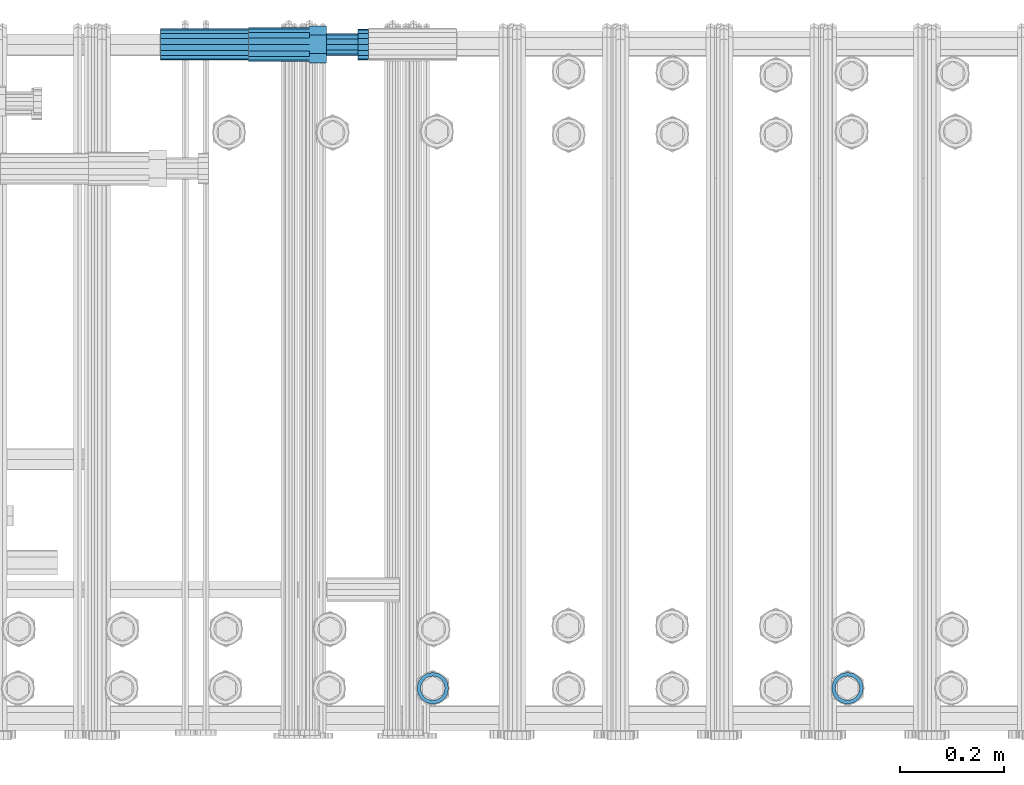
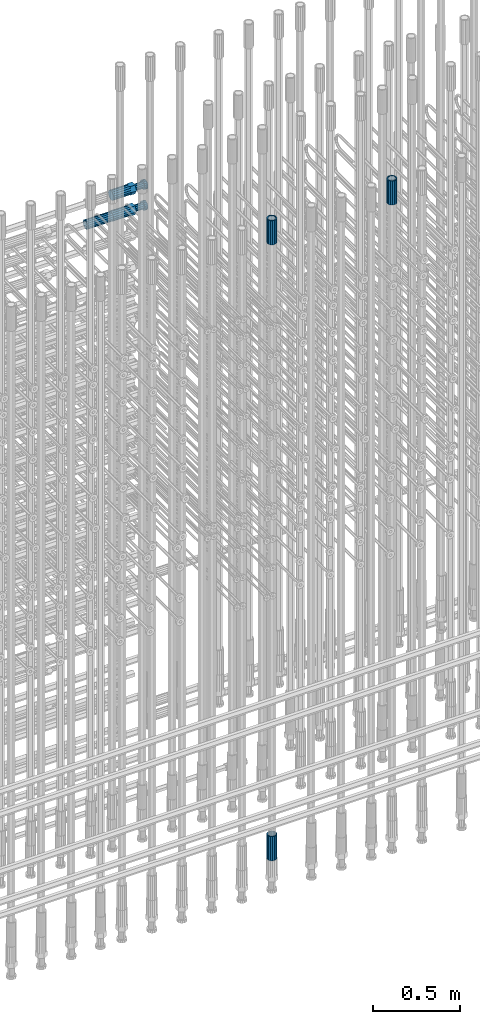
# One storey, part 56 of 177: 6 beams.
"""IFC2X3 building model written with IfcOpenShell, lengths in millimetres."""

from ifc_helpers import new_model, si_unit, frame, origin_with_axes, place, context, subcontext, project, spatial, faceted_brep, material, type_object, element, save


model = new_model("IFC2X3")

# Units and contexts
model_context_1 = context("Model", 3, precision=1e-05, world=origin_with_axes())
model_context_2 = context("Model", 3, precision=1e-05, world=origin_with_axes())
body_context = subcontext(model_context_2, "Body", "Model", "MODEL_VIEW")
ifc_project = project(units=[si_unit("LENGTHUNIT", "METRE", prefix="MILLI"), si_unit("AREAUNIT", "SQUARE_METRE"), si_unit("VOLUMEUNIT", "CUBIC_METRE"), si_unit("MASSUNIT", "GRAM", prefix="KILO"), si_unit("TIMEUNIT", "SECOND"), si_unit("PLANEANGLEUNIT", "RADIAN"), si_unit("SOLIDANGLEUNIT", "STERADIAN"), si_unit("THERMODYNAMICTEMPERATUREUNIT", "DEGREE_CELSIUS"), si_unit("LUMINOUSINTENSITYUNIT", "LUMEN")], contexts=[model_context_1])

# Site, building, storey
site_placement = place(None, origin_with_axes())
site = spatial("IfcSite", under=ifc_project, at=site_placement, CompositionType="ELEMENT")
building_placement = place(site_placement, origin_with_axes())
building = spatial("IfcBuilding", under=site, at=building_placement, Name="Undefined", CompositionType="ELEMENT")
storey_placement = place(building_placement, origin_with_axes())
storey = spatial("IfcBuildingStorey", under=building, at=storey_placement, Name="Undefined", CompositionType="ELEMENT", Elevation=0.0)

# Beams
ifc_material = material(Name="STEEL/S275")
beam_type_1 = type_object("IfcBeamType", PredefinedType="NOTDEFINED")
beam_1_placement = place(storey_placement, frame((2031974.00256183, 6205157.35759348, 22659.9858194822), z_axis=(1.0, 0.0, 0.0), x_axis=(0.0, 0.0, 1.0)))
element("IfcBeam", 1, at=beam_1_placement, inside=storey, type_object=beam_type_1, material=ifc_material, Name="AG40N", context=body_context, shape_type="Brep", body=[
    faceted_brep([(0.0, -23.5000000001164, -9.31322574615479e-10), (0.0, -21.7111690140155, 8.99306066054851), (170.0, -21.7111690140155, 8.99306066054851), (170.0, -23.5, 0.0), (0.0, -16.6170093578839, 16.6170093575493), (170.0, -16.6170093578839, 16.6170093575493), (0.0, -8.99306066057943, 21.7111690137535), (170.0, -8.99306066057943, 21.7111690137535), (0.0, 1.16415321826935e-10, 23.5), (170.0, 0.0, 23.5), (0.0, 8.99306066057943, 21.7111690137535), (170.0, 8.99306066057943, 21.7111690137535), (0.0, 16.6170093578839, 16.6170093575493), (170.0, 16.6170093578839, 16.6170093575493), (0.0, 21.7111690140155, 8.99306066054851), (170.0, 21.7111690140155, 8.99306066054851), (0.0, 23.5000000001164, -9.31322574615479e-10), (170.0, 23.5, 0.0), (0.0, 21.7111690140155, -8.99306066054851), (170.0, 21.7111690140155, -8.99306066054851), (0.0, 16.6170093578839, -16.6170093575493), (170.0, 16.6170093578839, -16.6170093575493), (0.0, 8.99306066057943, -21.7111690137535), (170.0, 8.99306066057943, -21.7111690137535), (0.0, 1.16415321826935e-10, -23.5000000009313), (170.0, 0.0, -23.5), (0.0, -8.99306066057943, -21.7111690137535), (170.0, -8.99306066057943, -21.7111690137535), (0.0, -16.6170093578839, -16.6170093575493), (170.0, -16.6170093578839, -16.6170093575493), (0.0, -21.7111690140155, -8.99306066054851), (170.0, -21.7111690140155, -8.99306066054851), (0.0, -30.5, 0.0), (0.0, -28.1783257415937, -11.6718446873128), (170.0, -28.1783257415937, -11.6718446873128), (170.0, -30.5, 0.0), (0.0, -21.5667568261888, -21.5667568258941), (170.0, -21.5667568261888, -21.5667568258941), (0.0, -11.6718446871346, -28.1783257415518), (170.0, -11.6718446871346, -28.1783257415518), (0.0, 0.0, -30.5), (170.0, 0.0, -30.5), (0.0, 11.6718446871346, -28.1783257415518), (170.0, 11.6718446871346, -28.1783257415518), (0.0, 21.5667568261888, -21.5667568258941), (170.0, 21.5667568261888, -21.5667568258941), (0.0, 28.1783257415937, -11.6718446873128), (170.0, 28.1783257415937, -11.6718446873128), (0.0, 30.5, 0.0), (170.0, 30.5, 0.0), (0.0, 28.1783257415937, 11.6718446873128), (170.0, 28.1783257415937, 11.6718446873128), (0.0, 21.5667568261888, 21.5667568258941), (170.0, 21.5667568261888, 21.5667568258941), (0.0, 11.6718446871346, 28.1783257415518), (170.0, 11.6718446871346, 28.1783257415518), (0.0, 0.0, 30.5), (170.0, 0.0, 30.5), (0.0, -11.6718446871346, 28.1783257415518), (170.0, -11.6718446871346, 28.1783257415518), (0.0, -21.5667568261888, 21.5667568258941), (170.0, -21.5667568261888, 21.5667568258941), (0.0, -28.1783257415937, 11.6718446873128), (170.0, -28.1783257415937, 11.6718446873128)], [[[0, 1, 2, 3]], [[1, 4, 5, 2]], [[4, 6, 7, 5]], [[6, 8, 9, 7]], [[8, 10, 11, 9]], [[10, 12, 13, 11]], [[12, 14, 15, 13]], [[14, 16, 17, 15]], [[16, 18, 19, 17]], [[18, 20, 21, 19]], [[20, 22, 23, 21]], [[22, 24, 25, 23]], [[24, 26, 27, 25]], [[26, 28, 29, 27]], [[28, 30, 31, 29]], [[30, 0, 3, 31]], [[32, 33, 34, 35]], [[33, 36, 37, 34]], [[36, 38, 39, 37]], [[38, 40, 41, 39]], [[40, 42, 43, 41]], [[42, 44, 45, 43]], [[44, 46, 47, 45]], [[46, 48, 49, 47]], [[48, 50, 51, 49]], [[50, 52, 53, 51]], [[52, 54, 55, 53]], [[54, 56, 57, 55]], [[56, 58, 59, 57]], [[58, 60, 61, 59]], [[60, 62, 63, 61]], [[62, 32, 35, 63]], [[37, 39, 41, 43, 45, 47, 49, 51, 53, 55, 57, 59, 61, 63, 35, 34], [5, 7, 9, 11, 13, 15, 17, 19, 21, 23, 25, 27, 29, 31, 3, 2]], [[62, 60, 58, 56, 54, 52, 50, 48, 46, 44, 42, 40, 38, 36, 33, 32], [30, 28, 26, 24, 22, 20, 18, 16, 14, 12, 10, 8, 6, 4, 1, 0]]]),
])
beam_2_placement = place(storey_placement, frame((2032774.00256055, 6205157.39829884, 22659.9858194822), z_axis=(1.0, 0.0, 0.0), x_axis=(0.0, 0.0, 1.0)))
element("IfcBeam", 2, at=beam_2_placement, inside=storey, type_object=beam_type_1, material=ifc_material, Name="AG40N", context=body_context, shape_type="Brep", body=[
    faceted_brep([(0.0, -23.5000000001164, -9.31322574615479e-10), (0.0, -21.7111690140155, 8.99306066054851), (170.0, -21.7111690140155, 8.99306066054851), (170.0, -23.5, 0.0), (0.0, -16.6170093578839, 16.6170093575493), (170.0, -16.6170093578839, 16.6170093575493), (0.0, -8.99306066057943, 21.7111690137535), (170.0, -8.99306066057943, 21.7111690137535), (0.0, 1.16415321826935e-10, 23.5), (170.0, 0.0, 23.5), (0.0, 8.99306066057943, 21.7111690137535), (170.0, 8.99306066057943, 21.7111690137535), (0.0, 16.6170093578839, 16.6170093575493), (170.0, 16.6170093578839, 16.6170093575493), (0.0, 21.7111690140155, 8.99306066054851), (170.0, 21.7111690140155, 8.99306066054851), (0.0, 23.5000000001164, -9.31322574615479e-10), (170.0, 23.5, 0.0), (0.0, 21.7111690140155, -8.99306066054851), (170.0, 21.7111690140155, -8.99306066054851), (0.0, 16.6170093578839, -16.6170093575493), (170.0, 16.6170093578839, -16.6170093575493), (0.0, 8.99306066057943, -21.7111690137535), (170.0, 8.99306066057943, -21.7111690137535), (0.0, 1.16415321826935e-10, -23.5000000009313), (170.0, 0.0, -23.5), (0.0, -8.99306066057943, -21.7111690137535), (170.0, -8.99306066057943, -21.7111690137535), (0.0, -16.6170093578839, -16.6170093575493), (170.0, -16.6170093578839, -16.6170093575493), (0.0, -21.7111690140155, -8.99306066054851), (170.0, -21.7111690140155, -8.99306066054851), (0.0, -30.5, 0.0), (0.0, -28.1783257415937, -11.6718446873128), (170.0, -28.1783257415937, -11.6718446873128), (170.0, -30.5, 0.0), (0.0, -21.5667568261888, -21.5667568258941), (170.0, -21.5667568261888, -21.5667568258941), (0.0, -11.6718446871346, -28.1783257415518), (170.0, -11.6718446871346, -28.1783257415518), (0.0, 0.0, -30.5), (170.0, 0.0, -30.5), (0.0, 11.6718446871346, -28.1783257415518), (170.0, 11.6718446871346, -28.1783257415518), (0.0, 21.5667568261888, -21.5667568258941), (170.0, 21.5667568261888, -21.5667568258941), (0.0, 28.1783257415937, -11.6718446873128), (170.0, 28.1783257415937, -11.6718446873128), (0.0, 30.5, 0.0), (170.0, 30.5, 0.0), (0.0, 28.1783257415937, 11.6718446873128), (170.0, 28.1783257415937, 11.6718446873128), (0.0, 21.5667568261888, 21.5667568258941), (170.0, 21.5667568261888, 21.5667568258941), (0.0, 11.6718446871346, 28.1783257415518), (170.0, 11.6718446871346, 28.1783257415518), (0.0, 0.0, 30.5), (170.0, 0.0, 30.5), (0.0, -11.6718446871346, 28.1783257415518), (170.0, -11.6718446871346, 28.1783257415518), (0.0, -21.5667568261888, 21.5667568258941), (170.0, -21.5667568261888, 21.5667568258941), (0.0, -28.1783257415937, 11.6718446873128), (170.0, -28.1783257415937, 11.6718446873128)], [[[0, 1, 2, 3]], [[1, 4, 5, 2]], [[4, 6, 7, 5]], [[6, 8, 9, 7]], [[8, 10, 11, 9]], [[10, 12, 13, 11]], [[12, 14, 15, 13]], [[14, 16, 17, 15]], [[16, 18, 19, 17]], [[18, 20, 21, 19]], [[20, 22, 23, 21]], [[22, 24, 25, 23]], [[24, 26, 27, 25]], [[26, 28, 29, 27]], [[28, 30, 31, 29]], [[30, 0, 3, 31]], [[32, 33, 34, 35]], [[33, 36, 37, 34]], [[36, 38, 39, 37]], [[38, 40, 41, 39]], [[40, 42, 43, 41]], [[42, 44, 45, 43]], [[44, 46, 47, 45]], [[46, 48, 49, 47]], [[48, 50, 51, 49]], [[50, 52, 53, 51]], [[52, 54, 55, 53]], [[54, 56, 57, 55]], [[56, 58, 59, 57]], [[58, 60, 61, 59]], [[60, 62, 63, 61]], [[62, 32, 35, 63]], [[37, 39, 41, 43, 45, 47, 49, 51, 53, 55, 57, 59, 61, 63, 35, 34], [5, 7, 9, 11, 13, 15, 17, 19, 21, 23, 25, 27, 29, 31, 3, 2]], [[62, 60, 58, 56, 54, 52, 50, 48, 46, 44, 42, 40, 38, 36, 33, 32], [30, 28, 26, 24, 22, 20, 18, 16, 14, 12, 10, 8, 6, 4, 1, 0]]]),
])
beam_3_placement = place(storey_placement, frame((2031974.00256183, 6205157.35759347, 18490.9668004279), z_axis=(-1.0, 0.0, 0.0), x_axis=(0.0, 0.0, -1.0)))
element("IfcBeam", 3, at=beam_3_placement, inside=storey, type_object=beam_type_1, material=ifc_material, Name="AG40N", context=body_context, shape_type="Brep", body=[
    faceted_brep([(0.0, -23.5000000001164, -9.31322574615479e-10), (0.0, -21.7111690140155, 8.99306066054851), (170.0, -21.7111690140155, 8.99306066054851), (170.0, -23.5, 0.0), (0.0, -16.6170093578839, 16.6170093575493), (170.0, -16.6170093578839, 16.6170093575493), (0.0, -8.99306066057943, 21.7111690137535), (170.0, -8.99306066057943, 21.7111690137535), (0.0, 1.16415321826935e-10, 23.5), (170.0, 0.0, 23.5), (0.0, 8.99306066057943, 21.7111690137535), (170.0, 8.99306066057943, 21.7111690137535), (0.0, 16.6170093578839, 16.6170093575493), (170.0, 16.6170093578839, 16.6170093575493), (0.0, 21.7111690140155, 8.99306066054851), (170.0, 21.7111690140155, 8.99306066054851), (0.0, 23.5000000001164, -9.31322574615479e-10), (170.0, 23.5, 0.0), (0.0, 21.7111690140155, -8.99306066054851), (170.0, 21.7111690140155, -8.99306066054851), (0.0, 16.6170093578839, -16.6170093575493), (170.0, 16.6170093578839, -16.6170093575493), (0.0, 8.99306066057943, -21.7111690137535), (170.0, 8.99306066057943, -21.7111690137535), (0.0, 1.16415321826935e-10, -23.5000000009313), (170.0, 0.0, -23.5), (0.0, -8.99306066057943, -21.7111690137535), (170.0, -8.99306066057943, -21.7111690137535), (0.0, -16.6170093578839, -16.6170093575493), (170.0, -16.6170093578839, -16.6170093575493), (0.0, -21.7111690140155, -8.99306066054851), (170.0, -21.7111690140155, -8.99306066054851), (0.0, -30.5, 0.0), (0.0, -28.1783257415937, -11.6718446873128), (170.0, -28.1783257415937, -11.6718446873128), (170.0, -30.5, 0.0), (0.0, -21.5667568261888, -21.5667568258941), (170.0, -21.5667568261888, -21.5667568258941), (0.0, -11.6718446871346, -28.1783257415518), (170.0, -11.6718446871346, -28.1783257415518), (0.0, 0.0, -30.5), (170.0, 0.0, -30.5), (0.0, 11.6718446871346, -28.1783257415518), (170.0, 11.6718446871346, -28.1783257415518), (0.0, 21.5667568261888, -21.5667568258941), (170.0, 21.5667568261888, -21.5667568258941), (0.0, 28.1783257415937, -11.6718446873128), (170.0, 28.1783257415937, -11.6718446873128), (0.0, 30.5, 0.0), (170.0, 30.5, 0.0), (0.0, 28.1783257415937, 11.6718446873128), (170.0, 28.1783257415937, 11.6718446873128), (0.0, 21.5667568261888, 21.5667568258941), (170.0, 21.5667568261888, 21.5667568258941), (0.0, 11.6718446871346, 28.1783257415518), (170.0, 11.6718446871346, 28.1783257415518), (0.0, 0.0, 30.5), (170.0, 0.0, 30.5), (0.0, -11.6718446871346, 28.1783257415518), (170.0, -11.6718446871346, 28.1783257415518), (0.0, -21.5667568261888, 21.5667568258941), (170.0, -21.5667568261888, 21.5667568258941), (0.0, -28.1783257415937, 11.6718446873128), (170.0, -28.1783257415937, 11.6718446873128)], [[[0, 1, 2, 3]], [[1, 4, 5, 2]], [[4, 6, 7, 5]], [[6, 8, 9, 7]], [[8, 10, 11, 9]], [[10, 12, 13, 11]], [[12, 14, 15, 13]], [[14, 16, 17, 15]], [[16, 18, 19, 17]], [[18, 20, 21, 19]], [[20, 22, 23, 21]], [[22, 24, 25, 23]], [[24, 26, 27, 25]], [[26, 28, 29, 27]], [[28, 30, 31, 29]], [[30, 0, 3, 31]], [[32, 33, 34, 35]], [[33, 36, 37, 34]], [[36, 38, 39, 37]], [[38, 40, 41, 39]], [[40, 42, 43, 41]], [[42, 44, 45, 43]], [[44, 46, 47, 45]], [[46, 48, 49, 47]], [[48, 50, 51, 49]], [[50, 52, 53, 51]], [[52, 54, 55, 53]], [[54, 56, 57, 55]], [[56, 58, 59, 57]], [[58, 60, 61, 59]], [[60, 62, 63, 61]], [[62, 32, 35, 63]], [[37, 39, 41, 43, 45, 47, 49, 51, 53, 55, 57, 59, 61, 63, 35, 34], [5, 7, 9, 11, 13, 15, 17, 19, 21, 23, 25, 27, 29, 31, 3, 2]], [[62, 60, 58, 56, 54, 52, 50, 48, 46, 44, 42, 40, 38, 36, 33, 32], [30, 28, 26, 24, 22, 20, 18, 16, 14, 12, 10, 8, 6, 4, 1, 0]]]),
])
beam_4_placement = place(storey_placement, frame((2031449.01847313, 6206398.98588032, 22212.9868004311), z_axis=(0.0, 0.0, -1.0), x_axis=(1.0, 0.0, 0.0)))
element("IfcBeam", 4, at=beam_4_placement, inside=storey, type_object=beam_type_1, material=ifc_material, Name="AG40N", context=body_context, shape_type="Brep", body=[
    faceted_brep([(0.0, -23.5000000001164, -9.31322574615479e-10), (0.0, -21.7111690140155, 8.99306066054851), (170.0, -21.7111690140155, 8.99306066054851), (170.0, -23.5, 0.0), (0.0, -16.6170093578839, 16.6170093575493), (170.0, -16.6170093578839, 16.6170093575493), (0.0, -8.99306066057943, 21.7111690137535), (170.0, -8.99306066057943, 21.7111690137535), (0.0, 1.16415321826935e-10, 23.5), (170.0, 0.0, 23.5), (0.0, 8.99306066057943, 21.7111690137535), (170.0, 8.99306066057943, 21.7111690137535), (0.0, 16.6170093578839, 16.6170093575493), (170.0, 16.6170093578839, 16.6170093575493), (0.0, 21.7111690140155, 8.99306066054851), (170.0, 21.7111690140155, 8.99306066054851), (0.0, 23.5000000001164, -9.31322574615479e-10), (170.0, 23.5, 0.0), (0.0, 21.7111690140155, -8.99306066054851), (170.0, 21.7111690140155, -8.99306066054851), (0.0, 16.6170093578839, -16.6170093575493), (170.0, 16.6170093578839, -16.6170093575493), (0.0, 8.99306066057943, -21.7111690137535), (170.0, 8.99306066057943, -21.7111690137535), (0.0, 1.16415321826935e-10, -23.5000000009313), (170.0, 0.0, -23.5), (0.0, -8.99306066057943, -21.7111690137535), (170.0, -8.99306066057943, -21.7111690137535), (0.0, -16.6170093578839, -16.6170093575493), (170.0, -16.6170093578839, -16.6170093575493), (0.0, -21.7111690140155, -8.99306066054851), (170.0, -21.7111690140155, -8.99306066054851), (0.0, -30.5, 0.0), (0.0, -28.1783257415937, -11.6718446873128), (170.0, -28.1783257415937, -11.6718446873128), (170.0, -30.5, 0.0), (0.0, -21.5667568261888, -21.5667568258941), (170.0, -21.5667568261888, -21.5667568258941), (0.0, -11.6718446871346, -28.1783257415518), (170.0, -11.6718446871346, -28.1783257415518), (0.0, 0.0, -30.5), (170.0, 0.0, -30.5), (0.0, 11.6718446871346, -28.1783257415518), (170.0, 11.6718446871346, -28.1783257415518), (0.0, 21.5667568261888, -21.5667568258941), (170.0, 21.5667568261888, -21.5667568258941), (0.0, 28.1783257415937, -11.6718446873128), (170.0, 28.1783257415937, -11.6718446873128), (0.0, 30.5, 0.0), (170.0, 30.5, 0.0), (0.0, 28.1783257415937, 11.6718446873128), (170.0, 28.1783257415937, 11.6718446873128), (0.0, 21.5667568261888, 21.5667568258941), (170.0, 21.5667568261888, 21.5667568258941), (0.0, 11.6718446871346, 28.1783257415518), (170.0, 11.6718446871346, 28.1783257415518), (0.0, 0.0, 30.5), (170.0, 0.0, 30.5), (0.0, -11.6718446871346, 28.1783257415518), (170.0, -11.6718446871346, 28.1783257415518), (0.0, -21.5667568261888, 21.5667568258941), (170.0, -21.5667568261888, 21.5667568258941), (0.0, -28.1783257415937, 11.6718446873128), (170.0, -28.1783257415937, 11.6718446873128)], [[[0, 1, 2, 3]], [[1, 4, 5, 2]], [[4, 6, 7, 5]], [[6, 8, 9, 7]], [[8, 10, 11, 9]], [[10, 12, 13, 11]], [[12, 14, 15, 13]], [[14, 16, 17, 15]], [[16, 18, 19, 17]], [[18, 20, 21, 19]], [[20, 22, 23, 21]], [[22, 24, 25, 23]], [[24, 26, 27, 25]], [[26, 28, 29, 27]], [[28, 30, 31, 29]], [[30, 0, 3, 31]], [[32, 33, 34, 35]], [[33, 36, 37, 34]], [[36, 38, 39, 37]], [[38, 40, 41, 39]], [[40, 42, 43, 41]], [[42, 44, 45, 43]], [[44, 46, 47, 45]], [[46, 48, 49, 47]], [[48, 50, 51, 49]], [[50, 52, 53, 51]], [[52, 54, 55, 53]], [[54, 56, 57, 55]], [[56, 58, 59, 57]], [[58, 60, 61, 59]], [[60, 62, 63, 61]], [[62, 32, 35, 63]], [[37, 39, 41, 43, 45, 47, 49, 51, 53, 55, 57, 59, 61, 63, 35, 34], [5, 7, 9, 11, 13, 15, 17, 19, 21, 23, 25, 27, 29, 31, 3, 2]], [[62, 60, 58, 56, 54, 52, 50, 48, 46, 44, 42, 40, 38, 36, 33, 32], [30, 28, 26, 24, 22, 20, 18, 16, 14, 12, 10, 8, 6, 4, 1, 0]]]),
])
beam_type_2 = type_object("IfcBeamType", Name="ROD65", PredefinedType="NOTDEFINED")
beam_5_placement = place(storey_placement, frame((2031619.01847313, 6206398.98588031, 22359.9868004311), z_axis=(0.0, 0.0, -1.0), x_axis=(1.0, 0.0, 0.0)))
element("IfcBeam", 5, at=beam_5_placement, inside=storey, type_object=beam_type_2, material=ifc_material, Name="AGB40", ObjectType="ROD65", context=body_context, shape_type="Brep", body=[
    faceted_brep([(117.0, 8.17543110251427, 30.873805644922), (117.0, 17.8250000001863, 30.873805644922), (117.0, 22.0056958701462, 23.6326279877685), (117.0, 12.4372115517035, 30.0260848065373), (117.0, -17.8250000001863, 30.873805644922), (150.200000000186, -17.8250000001863, 30.873805644922), (150.200000000186, 17.8250000001863, 30.873805644922), (117.0, -8.17543110251427, 30.873805644922), (117.0, -12.4372115517035, 30.0260848065373), (117.0, -22.0056958701462, 23.6326279877685), (117.0, -35.6500000003725, 0.0), (150.200000000186, -35.6500000003725, 0.0), (117.0, -30.8443150008097, 8.32369058486074), (117.0, -32.5, 0.0), (117.0, -30.8443150008097, -8.32369058462791), (117.0, -17.8250000001863, -30.873805644922), (150.200000000186, -17.8250000001863, -30.873805644922), (117.0, -22.0056958701462, -23.6326279877685), (117.0, -12.4372115517035, -30.0260848065373), (117.0, -8.17543110251427, -30.873805644922), (117.0, 17.8250000001863, -30.873805644922), (150.200000000186, 17.8250000001863, -30.873805644922), (117.0, 8.17543110251427, -30.873805644922), (117.0, 22.0056958701462, -23.6326279877685), (117.0, 12.4372115517035, -30.0260848065373), (117.0, 35.6500000003725, 0.0), (150.200000000186, 35.6500000003725, 0.0), (117.0, 30.8443150008097, -8.32369058486074), (117.0, 30.8443150008097, 8.32369058462791), (117.0, 32.5, 0.0), (0.0, -22.9809703892097, 22.9809703885621), (0.0, -30.0260848058388, 12.4372115518636), (117.0, -30.0260848067701, 12.4372115519363), (117.0, -22.9809703882784, 22.9809703885112), (-2.3283064365387e-10, 22.9809703892097, -22.9809703885639), (-4.65661287307739e-10, 30.0260848077014, -12.4372115518672), (117.0, 30.0260848067701, -12.4372115519363), (117.0, 22.9809703882784, -22.9809703885112), (-2.3283064365387e-10, -30.0260848067701, -12.4372115518672), (-2.3283064365387e-10, -22.9809703892097, -22.9809703885621), (117.0, -22.9809703882784, -22.9809703885112), (117.0, -30.0260848067701, -12.4372115519363), (-2.3283064365387e-10, -12.4372115507722, 30.0260848066137), (-2.3283064365387e-10, 9.31322574615479e-10, 32.4999999999982), (-2.3283064365387e-10, 12.4372115526348, 30.0260848066137), (0.0, 22.9809703892097, 22.9809703885621), (-2.3283064365387e-10, 30.0260848077014, 12.4372115518636), (-2.3283064365387e-10, 32.5, 0.0), (-2.3283064365387e-10, 12.4372115526348, -30.0260848066173), (-2.3283064365387e-10, 9.31322574615479e-10, -32.5), (-2.3283064365387e-10, -12.4372115517035, -30.0260848066173), (-4.65661287307739e-10, -32.4999999990687, -1.81898940354586e-12), (117.0, 22.9809703882784, 22.9809703885112), (117.0, 30.0260848067701, 12.4372115519363), (117.0, 0.0, -32.5), (117.0, 0.0, 32.5), (150.200000000186, 10.5, -18.1865334794857), (150.200000000186, 0.0, -21.0), (150.200000000186, -10.5, -18.1865334794857), (150.200000000186, -18.18653347902, -10.5), (150.200000000186, -21.0, 0.0), (150.200000000186, -18.18653347902, 10.5), (150.200000000186, -10.5, 18.1865334794857), (150.200000000186, 0.0, 21.0), (150.200000000186, 10.5, 18.1865334794857), (150.200000000186, 18.18653347902, 10.5), (150.200000000186, 21.0, 0.0), (150.200000000186, 18.18653347902, -10.5), (210.980000000447, -18.18653347902, 10.5), (210.980000000447, -21.0, 0.0), (210.980000000447, -10.5, 18.1865334794857), (210.980000000447, 0.0, 21.0), (210.980000000447, 10.5, 18.1865334794857), (210.980000000447, 18.18653347902, 10.5), (210.980000000447, 21.0, 0.0), (210.980000000447, 18.18653347902, -10.5), (210.980000000447, 10.5, -18.1865334794857), (210.980000000447, 0.0, -21.0), (210.980000000447, -10.5, -18.1865334794857), (210.980000000447, -18.18653347902, -10.5), (211.001368442696, -27.7269937992096, -11.491116326768), (211.003082550167, -21.2238094303757, -21.223815418547), (231.002518367059, -21.2131944671273, -21.2132004550658), (231.000804259587, -27.7163788359612, -11.4805013632867), (211.001368440451, -11.4911085031927, -27.7269970395137), (231.000804257343, -11.4804935399443, -27.7163820760325), (210.996487071217, -0.0106065049767494, -30.0106107392348), (230.995922888109, 8.45827162265778e-06, -29.9999957757536), (210.989181586672, 11.46989420522, -27.7269970329944), (230.988617403564, 11.4805091684684, -27.7163820695132), (210.980564180623, 21.2025914648548, -21.2238154064398), (230.979999997515, 21.2132064281031, -21.2132004429586), (210.971946775022, 27.7057703435421, -11.4911163107026), (230.971382591913, 27.7163853067905, -11.4805013472214), (210.96464129175, 29.9893808094785, -0.0106149562634528), (230.964077108642, 29.9999957727268, 7.21774995326996e-09), (210.959759924415, 27.7057638689876, 11.4698863970116), (230.959195741307, 27.7163788322359, 11.4805013604928), (210.958045816944, 21.2025795001537, 21.2025854887906), (230.957481633835, 21.213194463402, 21.2132004522718), (210.95975992666, 11.4698785729706, 27.7057671097573), (230.959195743551, 11.480493536219, 27.7163820732385), (210.964641295894, -0.010623425245285, 29.9893808094785), (230.964077112785, -8.46199691295624e-06, 29.9999957729597), (210.971946780439, -11.4911241354421, 27.705767103238), (230.97138259733, -11.4805091721937, 27.7163820667192), (210.980564186488, -21.2238213950768, 21.2025854766835), (230.980000003379, -21.2132064318284, 21.2132004401647), (210.989181592089, -27.7270002737641, 11.4698863809463), (230.988617408981, -27.7163853105158, 11.4805013444275), (210.996487075361, -30.0106107397005, -0.0106149734929204), (230.995922892253, -29.9999957764521, -1.00117176771164e-08)], [[[0, 1, 2, 3]], [[4, 5, 6, 1, 0, 7]], [[4, 7, 8, 9]], [[10, 11, 5, 4, 9, 12]], [[10, 12, 13, 14]], [[15, 16, 11, 10, 14, 17]], [[15, 17, 18, 19]], [[20, 21, 16, 15, 19, 22]], [[23, 20, 22, 24]], [[25, 26, 21, 20, 23, 27]], [[28, 25, 27, 29]], [[30, 31, 32, 33]], [[34, 35, 36, 37]], [[38, 39, 40, 41]], [[31, 30, 42, 43, 44, 45, 46, 47, 35, 34, 48, 49, 50, 39, 38, 51]], [[46, 45, 52, 53]], [[29, 47, 46, 53, 28]], [[27, 36, 35, 47, 29]], [[23, 37, 36, 27]], [[24, 48, 34, 37, 23]], [[22, 54, 49, 48, 24]], [[19, 54, 22]], [[18, 50, 49, 54, 19]], [[17, 40, 39, 50, 18]], [[14, 41, 40, 17]], [[13, 51, 38, 41, 14]], [[12, 32, 31, 51, 13]], [[9, 33, 32, 12]], [[8, 42, 30, 33, 9]], [[7, 55, 43, 42, 8]], [[0, 55, 7]], [[3, 44, 43, 55, 0]], [[2, 52, 45, 44, 3]], [[28, 53, 52, 2]], [[1, 6, 26, 25, 28, 2]], [[5, 11, 16, 21, 26, 6], [56, 57, 58, 59, 60, 61, 62, 63, 64, 65, 66, 67]], [[68, 61, 60, 69]], [[70, 62, 61, 68]], [[71, 63, 62, 70]], [[72, 64, 63, 71]], [[73, 65, 64, 72]], [[74, 66, 65, 73]], [[75, 67, 66, 74]], [[76, 56, 67, 75]], [[77, 57, 56, 76]], [[78, 58, 57, 77]], [[79, 59, 58, 78]], [[69, 60, 59, 79]], [[80, 81, 82, 83]], [[81, 84, 85, 82]], [[84, 86, 87, 85]], [[86, 88, 89, 87]], [[88, 90, 91, 89]], [[90, 92, 93, 91]], [[92, 94, 95, 93]], [[94, 96, 97, 95]], [[96, 98, 99, 97]], [[98, 100, 101, 99]], [[100, 102, 103, 101]], [[102, 104, 105, 103]], [[104, 106, 107, 105]], [[106, 108, 109, 107]], [[108, 110, 111, 109]], [[82, 85, 87, 89, 91, 93, 95, 97, 99, 101, 103, 105, 107, 109, 111, 83]], [[110, 80, 83, 111]], [[108, 106, 104, 102, 100, 98, 96, 94, 92, 90, 88, 86, 84, 81, 80, 110], [75, 74, 73, 72, 71, 70, 68, 69, 79, 78, 77, 76]]]),
])
beam_6_placement = place(storey_placement, frame((2031619.01847313, 6206398.98588032, 22212.9868004311), z_axis=(0.0, 0.0, -1.0), x_axis=(1.0, 0.0, 0.0)))
element("IfcBeam", 6, at=beam_6_placement, inside=storey, type_object=beam_type_2, material=ifc_material, Name="AGB40", ObjectType="ROD65", context=body_context, shape_type="Brep", body=[
    faceted_brep([(117.0, 8.17543110251427, 30.873805644922), (117.0, 17.8250000001863, 30.873805644922), (117.0, 22.0056958701462, 23.6326279877685), (117.0, 12.4372115517035, 30.0260848065373), (117.0, -17.8250000001863, 30.873805644922), (150.200000000186, -17.8250000001863, 30.873805644922), (150.200000000186, 17.8250000001863, 30.873805644922), (117.0, -8.17543110251427, 30.873805644922), (117.0, -12.4372115517035, 30.0260848065373), (117.0, -22.0056958701462, 23.6326279877685), (117.0, -35.6500000003725, 0.0), (150.200000000186, -35.6500000003725, 0.0), (117.0, -30.8443150008097, 8.32369058486074), (117.0, -32.5, 0.0), (117.0, -30.8443150008097, -8.32369058462791), (117.0, -17.8250000001863, -30.873805644922), (150.200000000186, -17.8250000001863, -30.873805644922), (117.0, -22.0056958701462, -23.6326279877685), (117.0, -12.4372115517035, -30.0260848065373), (117.0, -8.17543110251427, -30.873805644922), (117.0, 17.8250000001863, -30.873805644922), (150.200000000186, 17.8250000001863, -30.873805644922), (117.0, 8.17543110251427, -30.873805644922), (117.0, 22.0056958701462, -23.6326279877685), (117.0, 12.4372115517035, -30.0260848065373), (117.0, 35.6500000003725, 0.0), (150.200000000186, 35.6500000003725, 0.0), (117.0, 30.8443150008097, -8.32369058486074), (117.0, 30.8443150008097, 8.32369058462791), (117.0, 32.5, 0.0), (0.0, -22.9809703892097, 22.9809703885621), (0.0, -30.0260848058388, 12.4372115518636), (117.0, -30.0260848067701, 12.4372115519363), (117.0, -22.9809703882784, 22.9809703885112), (-2.3283064365387e-10, 22.9809703892097, -22.9809703885639), (-4.65661287307739e-10, 30.0260848077014, -12.4372115518672), (117.0, 30.0260848067701, -12.4372115519363), (117.0, 22.9809703882784, -22.9809703885112), (-2.3283064365387e-10, -30.0260848067701, -12.4372115518672), (-2.3283064365387e-10, -22.9809703892097, -22.9809703885621), (117.0, -22.9809703882784, -22.9809703885112), (117.0, -30.0260848067701, -12.4372115519363), (-2.3283064365387e-10, -12.4372115507722, 30.0260848066137), (-2.3283064365387e-10, 9.31322574615479e-10, 32.4999999999982), (-2.3283064365387e-10, 12.4372115526348, 30.0260848066137), (0.0, 22.9809703892097, 22.9809703885621), (-2.3283064365387e-10, 30.0260848077014, 12.4372115518636), (-2.3283064365387e-10, 32.5, 0.0), (-2.3283064365387e-10, 12.4372115526348, -30.0260848066173), (-2.3283064365387e-10, 9.31322574615479e-10, -32.5), (-2.3283064365387e-10, -12.4372115517035, -30.0260848066173), (-4.65661287307739e-10, -32.4999999990687, -1.81898940354586e-12), (117.0, 22.9809703882784, 22.9809703885112), (117.0, 30.0260848067701, 12.4372115519363), (117.0, 0.0, -32.5), (117.0, 0.0, 32.5), (150.200000000186, 10.5, -18.1865334794857), (150.200000000186, 0.0, -21.0), (150.200000000186, -10.5, -18.1865334794857), (150.200000000186, -18.18653347902, -10.5), (150.200000000186, -21.0, 0.0), (150.200000000186, -18.18653347902, 10.5), (150.200000000186, -10.5, 18.1865334794857), (150.200000000186, 0.0, 21.0), (150.200000000186, 10.5, 18.1865334794857), (150.200000000186, 18.18653347902, 10.5), (150.200000000186, 21.0, 0.0), (150.200000000186, 18.18653347902, -10.5), (210.980000000447, -18.18653347902, 10.5), (210.980000000447, -21.0, 0.0), (210.980000000447, -10.5, 18.1865334794857), (210.980000000447, 0.0, 21.0), (210.980000000447, 10.5, 18.1865334794857), (210.980000000447, 18.18653347902, 10.5), (210.980000000447, 21.0, 0.0), (210.980000000447, 18.18653347902, -10.5), (210.980000000447, 10.5, -18.1865334794857), (210.980000000447, 0.0, -21.0), (210.980000000447, -10.5, -18.1865334794857), (210.980000000447, -18.18653347902, -10.5), (211.001368442696, -27.7269937992096, -11.491116326768), (211.003082550167, -21.2238094303757, -21.223815418547), (231.002518367059, -21.2131944671273, -21.2132004550658), (231.000804259587, -27.7163788359612, -11.4805013632867), (211.001368440451, -11.4911085031927, -27.7269970395137), (231.000804257343, -11.4804935399443, -27.7163820760325), (210.996487071217, -0.0106065049767494, -30.0106107392348), (230.995922888109, 8.45827162265778e-06, -29.9999957757536), (210.989181586672, 11.46989420522, -27.7269970329944), (230.988617403564, 11.4805091684684, -27.7163820695132), (210.980564180623, 21.2025914648548, -21.2238154064398), (230.979999997515, 21.2132064281031, -21.2132004429586), (210.971946775022, 27.7057703435421, -11.4911163107026), (230.971382591913, 27.7163853067905, -11.4805013472214), (210.96464129175, 29.9893808094785, -0.0106149562634528), (230.964077108642, 29.9999957727268, 7.21774995326996e-09), (210.959759924415, 27.7057638689876, 11.4698863970116), (230.959195741307, 27.7163788322359, 11.4805013604928), (210.958045816944, 21.2025795001537, 21.2025854887906), (230.957481633835, 21.213194463402, 21.2132004522718), (210.95975992666, 11.4698785729706, 27.7057671097573), (230.959195743551, 11.480493536219, 27.7163820732385), (210.964641295894, -0.010623425245285, 29.9893808094785), (230.964077112785, -8.46199691295624e-06, 29.9999957729597), (210.971946780439, -11.4911241354421, 27.705767103238), (230.97138259733, -11.4805091721937, 27.7163820667192), (210.980564186488, -21.2238213950768, 21.2025854766835), (230.980000003379, -21.2132064318284, 21.2132004401647), (210.989181592089, -27.7270002737641, 11.4698863809463), (230.988617408981, -27.7163853105158, 11.4805013444275), (210.996487075361, -30.0106107397005, -0.0106149734929204), (230.995922892253, -29.9999957764521, -1.00117176771164e-08)], [[[0, 1, 2, 3]], [[4, 5, 6, 1, 0, 7]], [[4, 7, 8, 9]], [[10, 11, 5, 4, 9, 12]], [[10, 12, 13, 14]], [[15, 16, 11, 10, 14, 17]], [[15, 17, 18, 19]], [[20, 21, 16, 15, 19, 22]], [[23, 20, 22, 24]], [[25, 26, 21, 20, 23, 27]], [[28, 25, 27, 29]], [[30, 31, 32, 33]], [[34, 35, 36, 37]], [[38, 39, 40, 41]], [[31, 30, 42, 43, 44, 45, 46, 47, 35, 34, 48, 49, 50, 39, 38, 51]], [[46, 45, 52, 53]], [[29, 47, 46, 53, 28]], [[27, 36, 35, 47, 29]], [[23, 37, 36, 27]], [[24, 48, 34, 37, 23]], [[22, 54, 49, 48, 24]], [[19, 54, 22]], [[18, 50, 49, 54, 19]], [[17, 40, 39, 50, 18]], [[14, 41, 40, 17]], [[13, 51, 38, 41, 14]], [[12, 32, 31, 51, 13]], [[9, 33, 32, 12]], [[8, 42, 30, 33, 9]], [[7, 55, 43, 42, 8]], [[0, 55, 7]], [[3, 44, 43, 55, 0]], [[2, 52, 45, 44, 3]], [[28, 53, 52, 2]], [[1, 6, 26, 25, 28, 2]], [[5, 11, 16, 21, 26, 6], [56, 57, 58, 59, 60, 61, 62, 63, 64, 65, 66, 67]], [[68, 61, 60, 69]], [[70, 62, 61, 68]], [[71, 63, 62, 70]], [[72, 64, 63, 71]], [[73, 65, 64, 72]], [[74, 66, 65, 73]], [[75, 67, 66, 74]], [[76, 56, 67, 75]], [[77, 57, 56, 76]], [[78, 58, 57, 77]], [[79, 59, 58, 78]], [[69, 60, 59, 79]], [[80, 81, 82, 83]], [[81, 84, 85, 82]], [[84, 86, 87, 85]], [[86, 88, 89, 87]], [[88, 90, 91, 89]], [[90, 92, 93, 91]], [[92, 94, 95, 93]], [[94, 96, 97, 95]], [[96, 98, 99, 97]], [[98, 100, 101, 99]], [[100, 102, 103, 101]], [[102, 104, 105, 103]], [[104, 106, 107, 105]], [[106, 108, 109, 107]], [[108, 110, 111, 109]], [[82, 85, 87, 89, 91, 93, 95, 97, 99, 101, 103, 105, 107, 109, 111, 83]], [[110, 80, 83, 111]], [[108, 106, 104, 102, 100, 98, 96, 94, 92, 90, 88, 86, 84, 81, 80, 110], [75, 74, 73, 72, 71, 70, 68, 69, 79, 78, 77, 76]]]),
])

save(model, "model.ifc")
